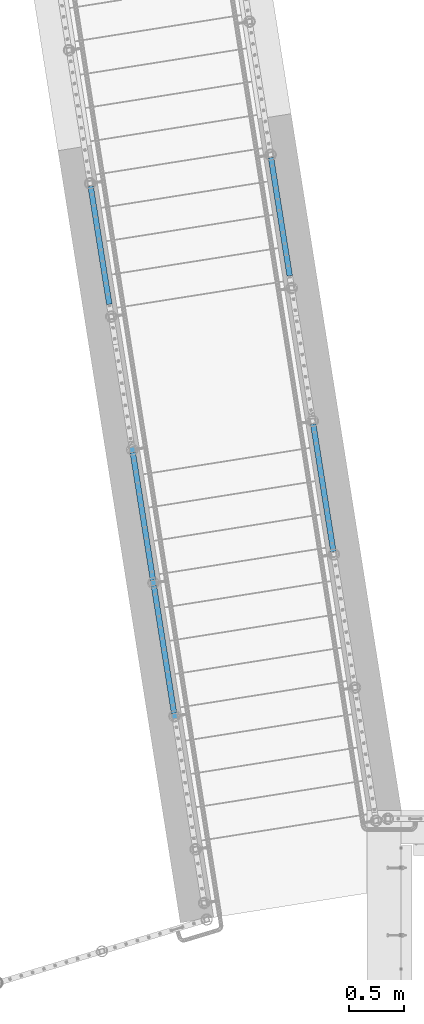
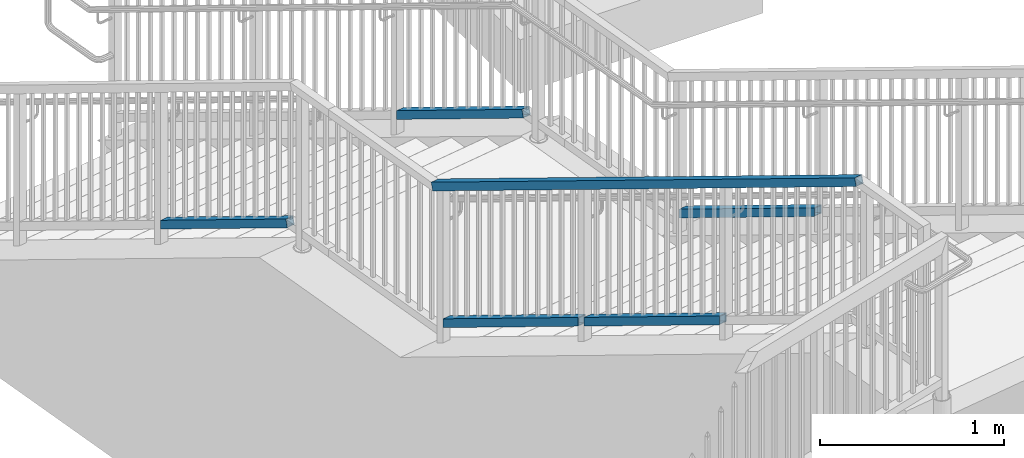
# One storey, part 321 of 975: 6 members.
"""IFC2X3 building model written with IfcOpenShell, lengths in millimetres."""

from ifc_helpers import new_model, si_unit, frame, origin_with_axes, place, context, subcontext, project, spatial, faceted_brep, material, type_object, element, save


model = new_model("IFC2X3")

# Units and contexts
model_context = context("Model", 3, precision=1e-05, world=origin_with_axes())
body_context = subcontext(model_context, "Body", "Model", "MODEL_VIEW")
ifc_project = project(units=[si_unit("LENGTHUNIT", "METRE", prefix="MILLI"), si_unit("AREAUNIT", "SQUARE_METRE"), si_unit("VOLUMEUNIT", "CUBIC_METRE"), si_unit("MASSUNIT", "GRAM", prefix="KILO"), si_unit("TIMEUNIT", "SECOND"), si_unit("PLANEANGLEUNIT", "RADIAN"), si_unit("SOLIDANGLEUNIT", "STERADIAN"), si_unit("THERMODYNAMICTEMPERATUREUNIT", "DEGREE_CELSIUS"), si_unit("LUMINOUSINTENSITYUNIT", "LUMEN")], contexts=[model_context])

# Site, building, storey
site_placement = place(None, origin_with_axes())
site = spatial("IfcSite", under=ifc_project, at=site_placement, CompositionType="ELEMENT")
building_placement = place(site_placement, origin_with_axes())
building = spatial("IfcBuilding", under=site, at=building_placement, Name="Undefined", CompositionType="ELEMENT")
storey_placement = place(building_placement, origin_with_axes())
storey = spatial("IfcBuildingStorey", under=building, at=storey_placement, Name="Undefined", CompositionType="ELEMENT", Elevation=0.0)

# Members
ifc_material = material()
member_type = type_object("IfcMemberType", Name="HSS2X2X.188_TUBES", PredefinedType="NOTDEFINED")
member_1_placement = place(storey_placement, frame((-1930.48766125361, 22792.559326444, 2871.82949693676), z_axis=(-0.987688340611262, -0.156434464938429, 0.0), x_axis=(-0.136949714005939, 0.864666463037498, -0.48331840802096)))
element("IfcMember", 1, at=member_1_placement, inside=storey, type_object=member_type, material=ifc_material, Name="HANDRAIL", ObjectType="HSS2X2X.188_TUBES", context=body_context, shape_type="Brep", body=[
    faceted_brep([(54.430359559261, 20.6375000000498, -20.6374999999766), (31.6431196181002, -20.6374999999789, -20.6374999999859), (1366.27296797945, -20.6374999992622, -20.6374999995212), (1389.05987018325, 20.6375000007629, -20.6374999995119), (31.6431196296326, -20.6375000000062, 20.6375000000085), (1366.27296799099, -20.6374999992895, 20.637500000473), (54.430359570797, 20.6375000000207, 20.6375000000166), (1389.05987019479, 20.6375000007356, 20.6375000004819), (57.0596564742154, 25.400000000056, -25.3999999999746), (57.0596564884145, 25.4000000000215, 25.4000000000174), (1391.68912814271, 25.4000000007363, 25.4000000004817), (1391.68912812851, 25.4000000007691, -25.3999999995108), (29.0138227146781, -25.4000000000106, 25.4000000000065), (1363.64371004573, -25.3999999992975, 25.4000000004712), (29.0138227004791, -25.3999999999778, -25.399999999986), (1363.64371003153, -25.3999999992629, -25.3999999995217)], [[[0, 1, 2, 3]], [[1, 4, 5, 2]], [[4, 6, 7, 5]], [[6, 0, 3, 7]], [[8, 9, 10, 11]], [[9, 12, 13, 10]], [[12, 14, 15, 13]], [[14, 8, 11, 15]], [[13, 15, 11, 10], [5, 7, 3, 2]], [[14, 12, 9, 8], [6, 4, 1, 0]]]),
])
member_2_placement = place(storey_placement, frame((-1808.73392049932, 22023.8364610111, 3301.51877837467), z_axis=(-0.987688340611262, -0.156434464938429, 0.0), x_axis=(-0.136949714005939, 0.864666463037498, -0.48331840802096)))
element("IfcMember", 2, at=member_2_placement, inside=storey, type_object=member_type, material=ifc_material, Name="HANDRAIL", ObjectType="HSS2X2X.188_TUBES", context=body_context, shape_type="Brep", body=[
    faceted_brep([(-449.193613397754, 20.6374999997788, -20.6375000001531), (-471.980853338919, -20.6375000002481, -20.6375000001619), (862.655224925733, -20.6374999995332, -20.6374999996974), (885.442464866897, 20.6375000004919, -20.6374999996883), (-471.980853327383, -20.6375000002754, 20.6374999998316), (862.655224937273, -20.6374999995605, 20.6375000002965), (-449.193613386218, 20.6374999997515, 20.6374999998411), (885.442464878433, 20.6375000004664, 20.6375000003059), (-446.564316482796, 25.399999999785, -25.4000000001511), (-446.564316468597, 25.3999999997504, 25.3999999998409), (888.071761796051, 25.4000000004671, 25.4000000003061), (888.071761781855, 25.400000000498, -25.3999999996865), (-474.610150242333, -25.4000000002816, 25.39999999983), (860.025928022314, -25.3999999995667, 25.4000000002948), (-474.610150256536, -25.4000000002488, -25.4000000001627), (860.025928008119, -25.399999999534, -25.3999999996975)], [[[0, 1, 2, 3]], [[1, 4, 5, 2]], [[4, 6, 7, 5]], [[6, 0, 3, 7]], [[8, 9, 10, 11]], [[9, 12, 13, 10]], [[12, 14, 15, 13]], [[14, 8, 11, 15]], [[13, 15, 11, 10], [5, 7, 3, 2]], [[14, 12, 9, 8], [6, 4, 1, 0]]]),
])
member_3_placement = place(storey_placement, frame((-1560.95816701181, 20459.441928129, 5083.16375357613), z_axis=(-0.987688340611262, -0.156434464938429, 0.0), x_axis=(-0.136949714005939, 0.864666463037498, -0.48331840802096)))
element("IfcMember", 3, at=member_3_placement, inside=storey, type_object=member_type, material=ifc_material, Name="HANDRAIL", ObjectType="HSS2X2X.188_TUBES", context=body_context, shape_type="Brep", body=[
    faceted_brep([(11.8642640238013, 20.6375000000335, -20.6374999999921), (1.22733809156853, -20.6375000000007, -20.6374999999969), (4179.21849894473, -20.63750000248, -20.6375000003829), (4189.85529405964, 20.6374999975196, -20.6375000003839), (1.22733724917089, -20.6375000000298, 20.6374999999966), (4179.21849904002, -20.6375000024382, 20.6374999996253), (11.8642631814091, 20.6375000000062, 20.6375000000016), (4189.85529415494, 20.6374999975615, 20.6374999996244), (13.0916017285726, 25.4000000000415, -25.399999999991), (13.091600691776, 25.4000000000069, 25.4000000000019), (4191.08261667918, 25.3999999975676, 25.3999999996249), (4191.0826165619, 25.3999999975131, -25.4000000003848), (0.0, -25.399999999976, 25.4000000000378), (4177.99117653777, -25.4000000024334, 25.3999999996261), (0.0, -25.400000000016, -25.4000000000196), (4177.99117642048, -25.4000000024844, -25.4000000003837)], [[[0, 1, 2, 3]], [[1, 4, 5, 2]], [[4, 6, 7, 5]], [[6, 0, 3, 7]], [[8, 9, 10, 11]], [[9, 12, 13, 10]], [[12, 14, 15, 13]], [[14, 8, 11, 15]], [[13, 15, 11, 10], [5, 7, 3, 2]], [[14, 12, 9, 8], [6, 4, 1, 0]]]),
])
member_4_placement = place(storey_placement, frame((-2329.49591164691, 25311.7968780976, 2136.76365059743), z_axis=(-0.987688340611262, -0.156434464938429, 0.0), x_axis=(-0.136949714005939, 0.864666463037498, -0.48331840802096)))
element("IfcMember", 4, at=member_4_placement, inside=storey, type_object=member_type, material=ifc_material, Name="HANDRAIL", ObjectType="HSS2X2X.188_TUBES", context=body_context, shape_type="Brep", body=[
    faceted_brep([(11.8642640238013, 20.6375000000335, -20.6374999999921), (1.22733809156853, -20.6375000000007, -20.6374999999969), (1238.06989042874, -20.6375000009048, -20.6375000003998), (1260.85713477887, 20.6374999991149, -20.63750000039), (1.22733724917089, -20.6375000000298, 20.6374999999966), (1238.06989043458, -20.6375000009411, 20.637499999598), (11.8642631814091, 20.6375000000062, 20.6375000000016), (1260.8571347847, 20.6374999990803, 20.6374999996078), (13.0916017285726, 25.4000000000415, -25.399999999991), (13.091600691776, 25.4000000000069, 25.4000000000019), (1263.48643221039, 25.3999999990792, 25.3999999996079), (1263.48643220321, 25.3999999991229, -25.4000000003882), (0.0, -25.399999999976, 25.4000000000378), (1235.44059301023, -25.4000000009455, 25.3999999995963), (0.0, -25.400000000016, -25.4000000000196), (1235.44059300306, -25.4000000009019, -25.4000000003998)], [[[0, 1, 2, 3]], [[1, 4, 5, 2]], [[4, 6, 7, 5]], [[6, 0, 3, 7]], [[8, 9, 10, 11]], [[9, 12, 13, 10]], [[12, 14, 15, 13]], [[14, 8, 11, 15]], [[13, 15, 11, 10], [5, 7, 3, 2]], [[14, 12, 9, 8], [6, 4, 1, 0]]]),
])
member_5_placement = place(storey_placement, frame((-299.620456977577, 23050.863315851, 2871.82949693674), z_axis=(0.987688352468583, 0.156434390074216, -6.09999983468464e-08), x_axis=(-0.136949714005939, 0.864666463037498, -0.48331840802096)))
element("IfcMember", 5, at=member_5_placement, inside=storey, type_object=member_type, material=ifc_material, Name="HANDRAIL", ObjectType="HSS2X2X.188_TUBES", context=body_context, shape_type="Brep", body=[
    faceted_brep([(31.6431248042572, 20.6375000000044, -20.6375000000007), (54.430365019809, -20.6375000000226, -20.6375000000116), (1389.0664456711, -20.6375000007483, -20.6375000003263), (1366.27920529597, 20.6374999992768, -20.6375000003163), (54.4303650082802, -20.6375000000462, 20.6374999999803), (1389.06644565957, -20.6375000007738, 20.6374999996651), (31.6431247927285, 20.6374999999753, 20.6374999999907), (1366.27920528444, 20.6374999992513, 20.6374999996756), (29.0138278576378, 25.4000000000106, -25.3999999999983), (29.0138278434497, 25.399999999976, 25.3999999999915), (1363.64990831675, 25.3999999992502, 25.3999999996763), (1363.64990833094, 25.3999999992848, -25.4000000003134), (57.0596619548996, -25.4000000000524, 25.3999999999778), (1391.6957426246, -25.4000000007818, 25.3999999996622), (57.0596619690841, -25.4000000000233, -25.4000000000124), (1391.69574263879, -25.4000000007491, -25.4000000003266)], [[[0, 1, 2, 3]], [[1, 4, 5, 2]], [[4, 6, 7, 5]], [[6, 0, 3, 7]], [[8, 9, 10, 11]], [[9, 12, 13, 10]], [[12, 14, 15, 13]], [[14, 8, 11, 15]], [[13, 15, 11, 10], [5, 7, 3, 2]], [[14, 12, 9, 8], [6, 4, 1, 0]]]),
])
member_6_placement = place(storey_placement, frame((-698.628276832682, 25570.100935698, 2136.76365059747), z_axis=(0.987688352468583, 0.156434390074216, -6.09999983468464e-08), x_axis=(-0.136949714005939, 0.864666463037498, -0.48331840802096)))
element("IfcMember", 6, at=member_6_placement, inside=storey, type_object=member_type, material=ifc_material, Name="HANDRAIL", ObjectType="HSS2X2X.188_TUBES", context=body_context, shape_type="Brep", body=[
    faceted_brep([(1.22733805137614, 20.6375000000317, -20.6374999999935), (11.864264413236, -20.6375000000044, -20.6375000000012), (1260.85712902391, -20.6374999990676, -20.6374999997406), (1238.06988494817, 20.6375000009557, -20.6374999997342), (11.8642640556318, -20.6375000000298, 20.6374999999916), (1260.85712901807, -20.6374999991003, 20.6375000002467), (1.2273376937701, 20.6375000000044, 20.6374999999994), (1238.06988494234, 20.6375000009175, 20.637500000254), (0.0, 25.3999999999724, -25.4000000000342), (0.0, 25.400000000016, 25.4000000000196), (1235.44058754831, 25.4000000009164, 25.4000000002538), (1235.44058755549, 25.4000000009601, -25.3999999997322), (13.0916016715055, -25.4000000000397, 25.3999999999892), (1263.48642641075, -25.3999999991102, 25.4000000002452), (13.0916021116373, -25.4000000000051, -25.4000000000015), (1263.48642641794, -25.3999999990647, -25.3999999997409)], [[[0, 1, 2, 3]], [[1, 4, 5, 2]], [[4, 6, 7, 5]], [[6, 0, 3, 7]], [[8, 9, 10, 11]], [[9, 12, 13, 10]], [[12, 14, 15, 13]], [[14, 8, 11, 15]], [[13, 15, 11, 10], [5, 7, 3, 2]], [[14, 12, 9, 8], [6, 4, 1, 0]]]),
])

save(model, "model.ifc")
